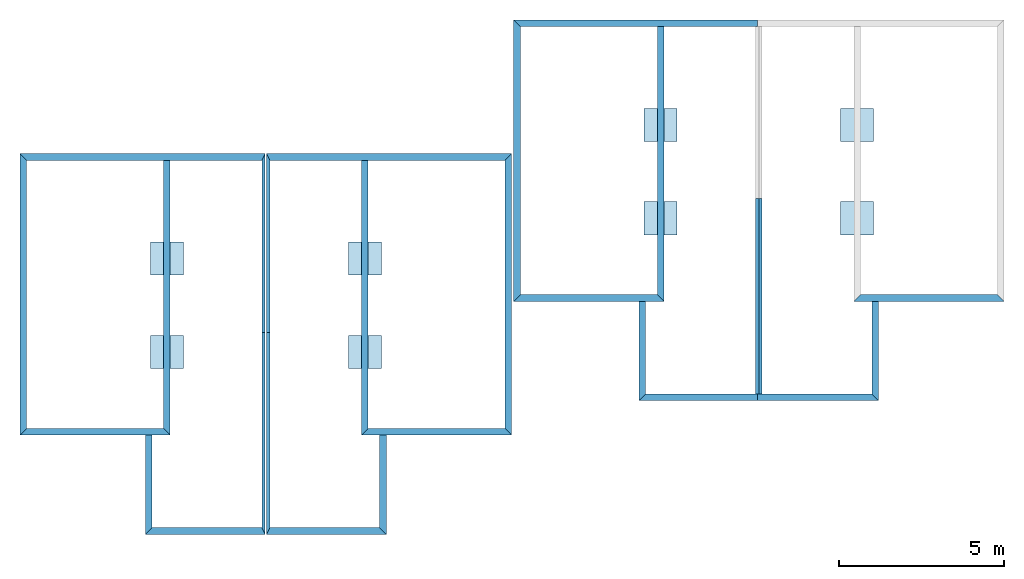
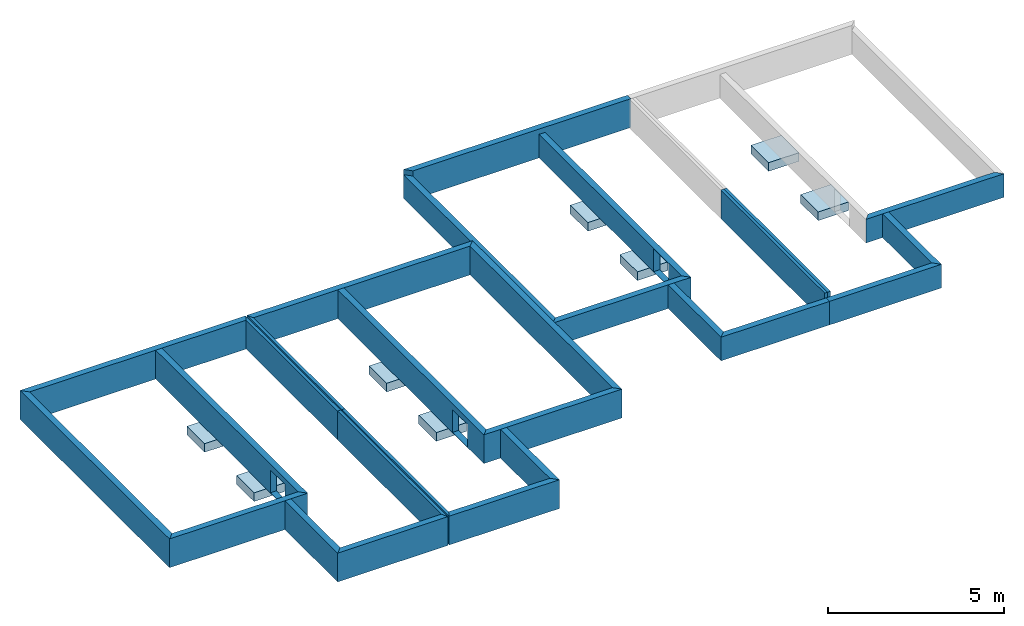
# One storey, part 1 of 2: 27 walls, 8 slabs, 3 openings.
"""IFC2X3 building model written with IfcOpenShell, lengths in metres."""

from ifc_helpers import new_model, entity, si_unit, converted_unit, derived_unit, money_unit, direction, frame, origin_with_axes, origin_2d_with_axis, place, context, subcontext, project, spatial, polyline, rectangle, outline, extrude, clip, halfspace, bounded_halfspace, faceted_brep, material, layer, layer_set, layer_usage, type_object, element, save


model = new_model("IFC2X3")

# Units and contexts
model_context = context("Model", 3, precision=1e-05, world=origin_with_axes(), true_north=direction((0.0, 1.0)))
body_context = subcontext(model_context, "Body", "Model", "MODEL_VIEW")
ifc_project = project(units=[si_unit("LENGTHUNIT", "METRE"), si_unit("AREAUNIT", "SQUARE_METRE"), si_unit("VOLUMEUNIT", "CUBIC_METRE"), converted_unit("PLANEANGLEUNIT", "DEGREE", entity("IfcPlaneAngleMeasure", 0.0174532925199), si_unit("PLANEANGLEUNIT", "RADIAN"), dimensions=[0, 0, 0, 0, 0, 0, 0]), si_unit("SOLIDANGLEUNIT", "STERADIAN"), money_unit("CHF"), converted_unit("TIMEUNIT", "Year", entity("IfcTimeMeasure", 31556926.0), si_unit("TIMEUNIT", "SECOND"), dimensions=[0, 0, 1, 0, 0, 0, 0]), si_unit("MASSUNIT", "GRAM", prefix="KILO"), si_unit("THERMODYNAMICTEMPERATUREUNIT", "DEGREE_CELSIUS"), si_unit("LUMINOUSINTENSITYUNIT", "LUMEN"), si_unit("ENERGYUNIT", "JOULE", prefix="MEGA"), derived_unit("THERMALCONDUCTANCEUNIT", [(si_unit("POWERUNIT", "WATT"), 1), (si_unit("LENGTHUNIT", "METRE"), -1), (si_unit("THERMODYNAMICTEMPERATUREUNIT", "KELVIN"), -1)]), derived_unit("SPECIFICHEATCAPACITYUNIT", [(si_unit("ENERGYUNIT", "JOULE"), 1), (si_unit("MASSUNIT", "GRAM", prefix="KILO"), -1), (si_unit("THERMODYNAMICTEMPERATUREUNIT", "KELVIN"), -1)]), derived_unit("MASSDENSITYUNIT", [(si_unit("MASSUNIT", "GRAM", prefix="KILO"), 1), (si_unit("VOLUMEUNIT", "CUBIC_METRE"), -1)])], contexts=[model_context])

# Site, building, storey
site_placement = place(None, origin_with_axes())
site = spatial("IfcSite", under=ifc_project, at=site_placement, CompositionType="ELEMENT")
building_placement = place(site_placement, origin_with_axes())
building = spatial("IfcBuilding", under=site, at=building_placement, CompositionType="ELEMENT")
storey_placement = place(building_placement, frame((0.0, 0.0, -0.8), z_axis=(0.0, 0.0, 1.0), x_axis=(1.0, 0.0, 0.0)))
storey = spatial("IfcBuildingStorey", under=building, at=storey_placement, Name="vs", CompositionType="ELEMENT", Elevation=-0.8)

# Slabs
ifc_material_1 = material()
slab_type_1 = type_object("IfcSlabType", Name="Dalle 1", PredefinedType="FLOOR")
slab_1_placement = place(storey_placement, origin_with_axes())
element("IfcSlab", 1, at=slab_1_placement, inside=storey, type_object=slab_type_1, material=ifc_material_1, Name="Base rectangulaire:1.00 x 1.00 x .30", PredefinedType="FLOOR", context=body_context, shape_type="Brep", body=[
    faceted_brep([(86.196785775, 89.777523968, -0.5), (86.196785775, 88.777523968, -0.5), (86.196785775, 88.777523968, -0.2), (86.196785775, 89.777523968, -0.2), (87.196785775, 89.777523968, -0.5), (87.196785775, 88.777523968, -0.5), (87.196785775, 88.777523968, -0.2), (87.196785775, 89.777523968, -0.2)], [[[0, 1, 2, 3]], [[0, 4, 5, 1]], [[1, 5, 6, 2]], [[3, 2, 6, 7]], [[4, 0, 3, 7]], [[5, 4, 7, 6]]]),
    faceted_brep([(86.196785775, 89.777523968, -0.5), (86.196785775, 88.777523968, -0.5), (86.196785775, 88.777523968, -0.2), (86.196785775, 89.777523968, -0.2), (87.196785775, 89.777523968, -0.5), (87.196785775, 88.777523968, -0.5), (87.196785775, 88.777523968, -0.2), (87.196785775, 89.777523968, -0.2)], [[[0, 1, 2, 3]], [[0, 4, 5, 1]], [[1, 5, 6, 2]], [[3, 2, 6, 7]], [[4, 0, 3, 7]], [[5, 4, 7, 6]]]),
])
slab_type_2 = type_object("IfcSlabType", Name="Dalle 2", PredefinedType="FLOOR")
slab_2_placement = place(storey_placement, origin_with_axes())
element("IfcSlab", 2, at=slab_2_placement, inside=storey, type_object=slab_type_2, material=ifc_material_1, Name="Base rectangulaire:1.00 x 1.00 x .30", PredefinedType="FLOOR", context=body_context, shape_type="Brep", body=[
    faceted_brep([(71.324626364, 85.7377566782, -0.5), (71.324626364, 84.7377566782, -0.5), (71.324626364, 84.7377566782, -0.2), (71.324626364, 85.7377566782, -0.2), (72.324626364, 85.7377566782, -0.5), (72.324626364, 84.7377566782, -0.5), (72.324626364, 84.7377566782, -0.2), (72.324626364, 85.7377566782, -0.2)], [[[0, 1, 2, 3]], [[0, 4, 5, 1]], [[1, 5, 6, 2]], [[3, 2, 6, 7]], [[4, 0, 3, 7]], [[5, 4, 7, 6]]]),
    faceted_brep([(71.324626364, 85.7377566782, -0.5), (71.324626364, 84.7377566782, -0.5), (71.324626364, 84.7377566782, -0.2), (71.324626364, 85.7377566782, -0.2), (72.324626364, 85.7377566782, -0.5), (72.324626364, 84.7377566782, -0.5), (72.324626364, 84.7377566782, -0.2), (72.324626364, 85.7377566782, -0.2)], [[[0, 1, 2, 3]], [[0, 4, 5, 1]], [[1, 5, 6, 2]], [[3, 2, 6, 7]], [[4, 0, 3, 7]], [[5, 4, 7, 6]]]),
])
slab_type_3 = type_object("IfcSlabType", Name="Dalle 3", PredefinedType="FLOOR")
slab_3_placement = place(storey_placement, origin_with_axes())
element("IfcSlab", 3, at=slab_3_placement, inside=storey, type_object=slab_type_3, material=ifc_material_1, Name="Base rectangulaire:1.00 x 1.00 x .30", PredefinedType="FLOOR", context=body_context, shape_type="Brep", body=[
    faceted_brep([(65.344626364, 84.7377566782, -0.5), (66.344626364, 84.7377566782, -0.5), (66.344626364, 84.7377566782, -0.2), (65.344626364, 84.7377566782, -0.2), (65.344626364, 85.7377566782, -0.5), (66.344626364, 85.7377566782, -0.5), (66.344626364, 85.7377566782, -0.2), (65.344626364, 85.7377566782, -0.2)], [[[0, 1, 2, 3]], [[0, 4, 5, 1]], [[1, 5, 6, 2]], [[3, 2, 6, 7]], [[4, 0, 3, 7]], [[5, 4, 7, 6]]]),
    faceted_brep([(65.344626364, 84.7377566782, -0.5), (66.344626364, 84.7377566782, -0.5), (66.344626364, 84.7377566782, -0.2), (65.344626364, 84.7377566782, -0.2), (65.344626364, 85.7377566782, -0.5), (66.344626364, 85.7377566782, -0.5), (66.344626364, 85.7377566782, -0.2), (65.344626364, 85.7377566782, -0.2)], [[[0, 1, 2, 3]], [[0, 4, 5, 1]], [[1, 5, 6, 2]], [[3, 2, 6, 7]], [[4, 0, 3, 7]], [[5, 4, 7, 6]]]),
])
slab_type_4 = type_object("IfcSlabType", Name="Dalle 4", PredefinedType="FLOOR")
slab_4_placement = place(storey_placement, origin_with_axes())
element("IfcSlab", 4, at=slab_4_placement, inside=storey, type_object=slab_type_4, material=ifc_material_1, Name="Base rectangulaire:1.00 x 1.00 x .30", PredefinedType="FLOOR", context=body_context, shape_type="Brep", body=[
    faceted_brep([(86.196785775, 86.957523968, -0.5), (86.196785775, 85.957523968, -0.5), (86.196785775, 85.957523968, -0.2), (86.196785775, 86.957523968, -0.2), (87.196785775, 86.957523968, -0.5), (87.196785775, 85.957523968, -0.5), (87.196785775, 85.957523968, -0.2), (87.196785775, 86.957523968, -0.2)], [[[0, 1, 2, 3]], [[0, 4, 5, 1]], [[1, 5, 6, 2]], [[3, 2, 6, 7]], [[4, 0, 3, 7]], [[5, 4, 7, 6]]]),
    faceted_brep([(86.196785775, 86.957523968, -0.5), (86.196785775, 85.957523968, -0.5), (86.196785775, 85.957523968, -0.2), (86.196785775, 86.957523968, -0.2), (87.196785775, 86.957523968, -0.5), (87.196785775, 85.957523968, -0.5), (87.196785775, 85.957523968, -0.2), (87.196785775, 86.957523968, -0.2)], [[[0, 1, 2, 3]], [[0, 4, 5, 1]], [[1, 5, 6, 2]], [[3, 2, 6, 7]], [[4, 0, 3, 7]], [[5, 4, 7, 6]]]),
])
slab_type_5 = type_object("IfcSlabType", Name="Dalle 5", PredefinedType="FLOOR")
slab_5_placement = place(storey_placement, origin_with_axes())
element("IfcSlab", 5, at=slab_5_placement, inside=storey, type_object=slab_type_5, material=ifc_material_1, Name="Base rectangulaire:1.00 x 1.00 x .30", PredefinedType="FLOOR", context=body_context, shape_type="Brep", body=[
    faceted_brep([(71.324626364, 82.9177566782, -0.5), (71.324626364, 81.9177566782, -0.5), (71.324626364, 81.9177566782, -0.2), (71.324626364, 82.9177566782, -0.2), (72.324626364, 82.9177566782, -0.5), (72.324626364, 81.9177566782, -0.5), (72.324626364, 81.9177566782, -0.2), (72.324626364, 82.9177566782, -0.2)], [[[0, 1, 2, 3]], [[0, 4, 5, 1]], [[1, 5, 6, 2]], [[3, 2, 6, 7]], [[4, 0, 3, 7]], [[5, 4, 7, 6]]]),
    faceted_brep([(71.324626364, 82.9177566782, -0.5), (71.324626364, 81.9177566782, -0.5), (71.324626364, 81.9177566782, -0.2), (71.324626364, 82.9177566782, -0.2), (72.324626364, 82.9177566782, -0.5), (72.324626364, 81.9177566782, -0.5), (72.324626364, 81.9177566782, -0.2), (72.324626364, 82.9177566782, -0.2)], [[[0, 1, 2, 3]], [[0, 4, 5, 1]], [[1, 5, 6, 2]], [[3, 2, 6, 7]], [[4, 0, 3, 7]], [[5, 4, 7, 6]]]),
])
slab_type_6 = type_object("IfcSlabType", Name="Dalle 6", PredefinedType="FLOOR")
slab_6_placement = place(storey_placement, origin_with_axes())
element("IfcSlab", 6, at=slab_6_placement, inside=storey, type_object=slab_type_6, material=ifc_material_1, Name="Base rectangulaire:1.00 x 1.00 x .30", PredefinedType="FLOOR", context=body_context, shape_type="Brep", body=[
    faceted_brep([(65.344626364, 81.9177566782, -0.5), (66.344626364, 81.9177566782, -0.5), (66.344626364, 81.9177566782, -0.2), (65.344626364, 81.9177566782, -0.2), (65.344626364, 82.9177566782, -0.5), (66.344626364, 82.9177566782, -0.5), (66.344626364, 82.9177566782, -0.2), (65.344626364, 82.9177566782, -0.2)], [[[0, 1, 2, 3]], [[0, 4, 5, 1]], [[1, 5, 6, 2]], [[3, 2, 6, 7]], [[4, 0, 3, 7]], [[5, 4, 7, 6]]]),
    faceted_brep([(65.344626364, 81.9177566782, -0.5), (66.344626364, 81.9177566782, -0.5), (66.344626364, 81.9177566782, -0.2), (65.344626364, 81.9177566782, -0.2), (65.344626364, 82.9177566782, -0.5), (66.344626364, 82.9177566782, -0.5), (66.344626364, 82.9177566782, -0.2), (65.344626364, 82.9177566782, -0.2)], [[[0, 1, 2, 3]], [[0, 4, 5, 1]], [[1, 5, 6, 2]], [[3, 2, 6, 7]], [[4, 0, 3, 7]], [[5, 4, 7, 6]]]),
])
slab_type_7 = type_object("IfcSlabType", Name="Dalle 7", PredefinedType="FLOOR")
slab_7_placement = place(storey_placement, origin_with_axes())
element("IfcSlab", 7, at=slab_7_placement, inside=storey, type_object=slab_type_7, material=ifc_material_1, Name="Base rectangulaire:1.00 x 1.00 x .30", PredefinedType="FLOOR", context=body_context, shape_type="Brep", body=[
    faceted_brep([(80.2610189554, 88.777523968, -0.5), (81.2610189554, 88.777523968, -0.5), (81.2610189554, 88.777523968, -0.2), (80.2610189554, 88.777523968, -0.2), (80.2610189554, 89.777523968, -0.5), (81.2610189554, 89.777523968, -0.5), (81.2610189554, 89.777523968, -0.2), (80.2610189554, 89.777523968, -0.2)], [[[0, 1, 2, 3]], [[0, 4, 5, 1]], [[1, 5, 6, 2]], [[3, 2, 6, 7]], [[4, 0, 3, 7]], [[5, 4, 7, 6]]]),
    faceted_brep([(80.2610189554, 88.777523968, -0.5), (81.2610189554, 88.777523968, -0.5), (81.2610189554, 88.777523968, -0.2), (80.2610189554, 88.777523968, -0.2), (80.2610189554, 89.777523968, -0.5), (81.2610189554, 89.777523968, -0.5), (81.2610189554, 89.777523968, -0.2), (80.2610189554, 89.777523968, -0.2)], [[[0, 1, 2, 3]], [[0, 4, 5, 1]], [[1, 5, 6, 2]], [[3, 2, 6, 7]], [[4, 0, 3, 7]], [[5, 4, 7, 6]]]),
])
slab_type_8 = type_object("IfcSlabType", Name="Dalle 8", PredefinedType="FLOOR")
slab_8_placement = place(storey_placement, origin_with_axes())
element("IfcSlab", 8, at=slab_8_placement, inside=storey, type_object=slab_type_8, material=ifc_material_1, Name="Base rectangulaire:1.00 x 1.00 x .30", PredefinedType="FLOOR", context=body_context, shape_type="Brep", body=[
    faceted_brep([(80.2610189554, 85.957523968, -0.5), (81.2610189554, 85.957523968, -0.5), (81.2610189554, 85.957523968, -0.2), (80.2610189554, 85.957523968, -0.2), (80.2610189554, 86.957523968, -0.5), (81.2610189554, 86.957523968, -0.5), (81.2610189554, 86.957523968, -0.2), (80.2610189554, 86.957523968, -0.2)], [[[0, 1, 2, 3]], [[0, 4, 5, 1]], [[1, 5, 6, 2]], [[3, 2, 6, 7]], [[4, 0, 3, 7]], [[5, 4, 7, 6]]]),
    faceted_brep([(80.2610189554, 85.957523968, -0.5), (81.2610189554, 85.957523968, -0.5), (81.2610189554, 85.957523968, -0.2), (80.2610189554, 85.957523968, -0.2), (80.2610189554, 86.957523968, -0.5), (81.2610189554, 86.957523968, -0.5), (81.2610189554, 86.957523968, -0.2), (80.2610189554, 86.957523968, -0.2)], [[[0, 1, 2, 3]], [[0, 4, 5, 1]], [[1, 5, 6, 2]], [[3, 2, 6, 7]], [[4, 0, 3, 7]], [[5, 4, 7, 6]]]),
])

# Walls
ifc_material_2 = material(Name="Parpaing")
ifc_layer_1 = layer(ifc_material_2, 0.2, ventilated="UNKNOWN")
ifc_layer_set_1 = layer_set([ifc_layer_1], Name="Parpaing 0.2")
ifc_layer_usage_1 = layer_usage(ifc_layer_set_1, "AXIS2", "POSITIVE", -0.1)
wall_type_1 = type_object("IfcWallType", Name="Mur de base:Ext. Parpaing 20", PredefinedType="STANDARD")
wall_1_placement = place(storey_placement, frame((91.0350487235, 84.047523968, -0.2), z_axis=(0.0, 0.0, 1.0), x_axis=(-1.0, 0.0, 0.0)))
element("IfcWallStandardCase", 9, at=wall_1_placement, inside=storey, type_object=wall_type_1, material=ifc_layer_usage_1, Name="Mur de base:Ext. Parpaing 20", ObjectType="STANDARD", context=body_context, shape_type="Clipping", body=[
    clip(extrude(outline(polyline([(0.1, -0.1), (4.23826294855, -0.1), (4.43826294855, 0.1), (-0.1, 0.1), (0.1, -0.1)])), origin_with_axes(), (0.0, 0.0, 1.0), 0.82), bounded_halfspace(frame((0.0, 0.0, 0.82), z_axis=(0.0, 0.0, -1.0), x_axis=(0.0, 1.0, 0.0)), True, origin_with_axes(), polyline([(3.88826292789, -0.11), (8.85786987799, -0.11), (8.85786987799, 0.11), (3.88826292789, 0.11), (3.88826292789, -0.11)]))),
])
ifc_layer_usage_2 = layer_usage(ifc_layer_set_1, "AXIS2", "POSITIVE", -0.1)
wall_2_placement = place(storey_placement, frame((83.6810189554, 81.047523968, -0.2), z_axis=(0.0, 0.0, 1.0), x_axis=(1.0, 0.0, 0.0)))
element("IfcWallStandardCase", 10, at=wall_2_placement, inside=storey, type_object=wall_type_1, material=ifc_layer_usage_2, Name="Mur de base:Ext. Parpaing 20", ObjectType="STANDARD", context=body_context, shape_type="SweptSolid", body=[
    extrude(outline(polyline([(0.0, -0.1), (3.66576681958, -0.1), (3.46576681958, 0.1), (0.0, 0.1), (0.0, -0.1)])), origin_with_axes(), (0.0, 0.0, 1.0), 0.82),
])
ifc_layer_usage_3 = layer_usage(ifc_layer_set_1, "AXIS2", "POSITIVE", -0.1)
wall_3_placement = place(storey_placement, frame((87.246785775, 81.047523968, -0.2), z_axis=(0.0, 0.0, 1.0), x_axis=(0.0, 1.0, 0.0)))
element("IfcWallStandardCase", 11, at=wall_3_placement, inside=storey, type_object=wall_type_1, material=ifc_layer_usage_3, Name="Mur de base:Ext. Parpaing 20", ObjectType="STANDARD", context=body_context, shape_type="SweptSolid", body=[
    extrude(outline(polyline([(-0.1, -0.1), (2.9, -0.1), (2.9, 0.1), (0.1, 0.1), (-0.1, -0.1)])), origin_with_axes(), (0.0, 0.0, 1.0), 0.82),
])
ifc_layer_usage_4 = layer_usage(ifc_layer_set_1, "AXIS2", "POSITIVE", -0.1)
wall_4_placement = place(storey_placement, frame((68.904626364, 88.3077566782, -0.2), z_axis=(0.0, 0.0, 1.0), x_axis=(1.0, 0.0, 0.0)))
element("IfcWallStandardCase", 12, at=wall_4_placement, inside=storey, type_object=wall_type_1, material=ifc_layer_usage_4, Name="Mur de base:Ext. Parpaing 20", ObjectType="STANDARD", context=body_context, shape_type="SweptSolid", body=[
    extrude(outline(polyline([(0.05, -0.1), (7.15826294855, -0.1), (7.35826294855, 0.1), (-0.05, 0.1), (0.05, -0.1)])), origin_with_axes(), (0.0, 0.0, 1.0), 1.0),
])
ifc_layer_usage_5 = layer_usage(ifc_layer_set_1, "AXIS2", "POSITIVE", -0.1)
wall_5_placement = place(storey_placement, frame((76.1628893125, 88.3077566782, -0.2), z_axis=(0.0, 0.0, 1.0), x_axis=(0.0, -1.0, 0.0)))
element("IfcWallStandardCase", 13, at=wall_5_placement, inside=storey, type_object=wall_type_1, material=ifc_layer_usage_5, Name="Mur de base:Ext. Parpaing 20", ObjectType="STANDARD", context=body_context, shape_type="SweptSolid", body=[
    extrude(outline(polyline([(0.1, -0.1), (8.2, -0.1), (8.4, 0.1), (-0.1, 0.1), (0.1, -0.1)])), origin_with_axes(), (0.0, 0.0, 1.0), 1.0),
])
ifc_layer_usage_6 = layer_usage(ifc_layer_set_1, "AXIS2", "POSITIVE", -0.1)
wall_6_placement = place(storey_placement, frame((76.1628893125, 80.0077566782, -0.2), z_axis=(0.0, 0.0, 1.0), x_axis=(-1.0, 0.0, 0.0)))
element("IfcWallStandardCase", 14, at=wall_6_placement, inside=storey, type_object=wall_type_1, material=ifc_layer_usage_6, Name="Mur de base:Ext. Parpaing 20", ObjectType="STANDARD", context=body_context, shape_type="SweptSolid", body=[
    extrude(outline(polyline([(0.1, -0.1), (4.23826294855, -0.1), (4.43826294855, 0.1), (-0.1, 0.1), (0.1, -0.1)])), origin_with_axes(), (0.0, 0.0, 1.0), 1.0),
])
ifc_layer_usage_7 = layer_usage(ifc_layer_set_1, "AXIS2", "POSITIVE", -0.1)
wall_7_placement = place(storey_placement, frame((68.904626364, 77.0077566782, -0.2), z_axis=(0.0, 0.0, 1.0), x_axis=(1.0, 0.0, 0.0)))
element("IfcWallStandardCase", 15, at=wall_7_placement, inside=storey, type_object=wall_type_1, material=ifc_layer_usage_7, Name="Mur de base:Ext. Parpaing 20", ObjectType="STANDARD", context=body_context, shape_type="SweptSolid", body=[
    extrude(outline(polyline([(-0.05, -0.1), (3.57, -0.1), (3.37, 0.1), (0.05, 0.1), (-0.05, -0.1)])), origin_with_axes(), (0.0, 0.0, 1.0), 1.0),
])
ifc_layer_usage_8 = layer_usage(ifc_layer_set_1, "AXIS2", "POSITIVE", -0.1)
wall_8_placement = place(storey_placement, frame((72.374626364, 77.0077566782, -0.2), z_axis=(0.0, 0.0, 1.0), x_axis=(0.0, 1.0, 0.0)))
element("IfcWallStandardCase", 16, at=wall_8_placement, inside=storey, type_object=wall_type_1, material=ifc_layer_usage_8, Name="Mur de base:Ext. Parpaing 20", ObjectType="STANDARD", context=body_context, shape_type="SweptSolid", body=[
    extrude(outline(polyline([(-0.1, -0.1), (2.9, -0.1), (2.9, 0.1), (0.1, 0.1), (-0.1, -0.1)])), origin_with_axes(), (0.0, 0.0, 1.0), 1.0),
])

# Wall, opening
ifc_layer_usage_9 = layer_usage(ifc_layer_set_1, "AXIS2", "POSITIVE", -0.1)
wall_9_placement = place(storey_placement, frame((71.824626364, 80.0077566782, -0.2), z_axis=(0.0, 0.0, 1.0), x_axis=(0.0, 1.0, 0.0)))
wall_9 = element("IfcWallStandardCase", 17, at=wall_9_placement, inside=storey, type_object=wall_type_1, material=ifc_layer_usage_9, Name="Mur de base:Ext. Parpaing 20", ObjectType="STANDARD", context=body_context, shape_type="SweptSolid", body=[
    extrude(outline(polyline([(0.1, -0.1), (8.2, -0.1), (8.2, 0.1), (-0.1, 0.1), (0.1, -0.1)])), origin_with_axes(), (0.0, 0.0, 1.0), 1.0),
])
opening_1_placement = place(wall_9_placement, frame((-80.0077566782, 71.824626364, 1.0), z_axis=(0.0, 0.0, 1.0), x_axis=(0.0, -1.0, 0.0)))
element("IfcOpeningElement", 18, at=opening_1_placement, cuts=wall_9, Name="Mur de base:Ext. Parpaing 20", context=body_context, shape_type="SweptSolid", body=[
    extrude(rectangle(XDim=0.793145708582, YDim=0.840999406834, at=origin_2d_with_axis()), frame((71.924626364, 81.266599442, -0.596572854291), z_axis=(-1.0, 0.0, 0.0), x_axis=(0.0, 0.0, -1.0)), (0.0, 0.0, 1.0), 0.2),
])

# Walls
ifc_layer_usage_10 = layer_usage(ifc_layer_set_1, "AXIS2", "POSITIVE", -0.1)
wall_10_placement = place(storey_placement, frame((68.764626364, 88.3077566782, -0.2), z_axis=(0.0, 0.0, 1.0), x_axis=(-1.0, 0.0, 0.0)))
element("IfcWallStandardCase", 19, at=wall_10_placement, inside=storey, type_object=wall_type_1, material=ifc_layer_usage_10, Name="Mur de base:Ext. Parpaing 20", ObjectType="STANDARD", context=body_context, shape_type="SweptSolid", body=[
    extrude(outline(polyline([(-0.05, -0.1), (7.35826294855, -0.1), (7.15826294855, 0.1), (0.05, 0.1), (-0.05, -0.1)])), origin_with_axes(), (0.0, 0.0, 1.0), 1.0),
])
ifc_layer_usage_11 = layer_usage(ifc_layer_set_1, "AXIS2", "POSITIVE", -0.1)
wall_11_placement = place(storey_placement, frame((61.5063634154, 88.3077566782, -0.2), z_axis=(0.0, 0.0, 1.0), x_axis=(0.0, -1.0, 0.0)))
element("IfcWallStandardCase", 20, at=wall_11_placement, inside=storey, type_object=wall_type_1, material=ifc_layer_usage_11, Name="Mur de base:Ext. Parpaing 20", ObjectType="STANDARD", context=body_context, shape_type="SweptSolid", body=[
    extrude(outline(polyline([(-0.1, -0.1), (8.4, -0.1), (8.2, 0.1), (0.1, 0.1), (-0.1, -0.1)])), origin_with_axes(), (0.0, 0.0, 1.0), 1.0),
])
ifc_layer_usage_12 = layer_usage(ifc_layer_set_1, "AXIS2", "POSITIVE", -0.1)
wall_12_placement = place(storey_placement, frame((61.5063634154, 80.0077566782, -0.2), z_axis=(0.0, 0.0, 1.0), x_axis=(1.0, 0.0, 0.0)))
element("IfcWallStandardCase", 21, at=wall_12_placement, inside=storey, type_object=wall_type_1, material=ifc_layer_usage_12, Name="Mur de base:Ext. Parpaing 20", ObjectType="STANDARD", context=body_context, shape_type="SweptSolid", body=[
    extrude(outline(polyline([(-0.1, -0.1), (4.43826294855, -0.1), (4.23826294855, 0.1), (0.1, 0.1), (-0.1, -0.1)])), origin_with_axes(), (0.0, 0.0, 1.0), 1.0),
])
ifc_layer_usage_13 = layer_usage(ifc_layer_set_1, "AXIS2", "POSITIVE", -0.1)
wall_13_placement = place(storey_placement, frame((68.764626364, 77.0077566782, -0.2), z_axis=(0.0, 0.0, 1.0), x_axis=(-1.0, 0.0, 0.0)))
element("IfcWallStandardCase", 22, at=wall_13_placement, inside=storey, type_object=wall_type_1, material=ifc_layer_usage_13, Name="Mur de base:Ext. Parpaing 20", ObjectType="STANDARD", context=body_context, shape_type="SweptSolid", body=[
    extrude(outline(polyline([(0.05, -0.1), (3.37, -0.1), (3.57, 0.1), (-0.05, 0.1), (0.05, -0.1)])), origin_with_axes(), (0.0, 0.0, 1.0), 1.0),
])
ifc_layer_usage_14 = layer_usage(ifc_layer_set_1, "AXIS2", "POSITIVE", -0.1)
wall_14_placement = place(storey_placement, frame((65.294626364, 77.0077566782, -0.2), z_axis=(0.0, 0.0, 1.0), x_axis=(0.0, 1.0, 0.0)))
element("IfcWallStandardCase", 23, at=wall_14_placement, inside=storey, type_object=wall_type_1, material=ifc_layer_usage_14, Name="Mur de base:Ext. Parpaing 20", ObjectType="STANDARD", context=body_context, shape_type="SweptSolid", body=[
    extrude(outline(polyline([(0.1, -0.1), (2.9, -0.1), (2.9, 0.1), (-0.1, 0.1), (0.1, -0.1)])), origin_with_axes(), (0.0, 0.0, 1.0), 1.0),
])

# Wall, opening
ifc_layer_usage_15 = layer_usage(ifc_layer_set_1, "AXIS2", "POSITIVE", -0.1)
wall_15_placement = place(storey_placement, frame((65.844626364, 80.0077566782, -0.2), z_axis=(0.0, 0.0, 1.0), x_axis=(0.0, 1.0, 0.0)))
wall_15 = element("IfcWallStandardCase", 24, at=wall_15_placement, inside=storey, type_object=wall_type_1, material=ifc_layer_usage_15, Name="Mur de base:Ext. Parpaing 20", ObjectType="STANDARD", context=body_context, shape_type="SweptSolid", body=[
    extrude(outline(polyline([(-0.1, -0.1), (8.2, -0.1), (8.2, 0.1), (0.1, 0.1), (-0.1, -0.1)])), origin_with_axes(), (0.0, 0.0, 1.0), 1.0),
])
opening_2_placement = place(wall_15_placement, frame((-80.0077566782, 65.844626364, 1.0), z_axis=(0.0, 0.0, 1.0), x_axis=(0.0, -1.0, 0.0)))
element("IfcOpeningElement", 25, at=opening_2_placement, cuts=wall_15, Name="Mur de base:Ext. Parpaing 20", context=body_context, shape_type="SweptSolid", body=[
    extrude(rectangle(XDim=0.793145708582, YDim=0.840999406834, at=origin_2d_with_axis()), frame((65.944626364, 81.266599442, -0.596572854291), z_axis=(-1.0, 0.0, 0.0), x_axis=(0.0, 0.0, -1.0)), (0.0, 0.0, 1.0), 0.2),
])

# Walls
ifc_layer_usage_16 = layer_usage(ifc_layer_set_1, "AXIS2", "POSITIVE", -0.1)
wall_16_placement = place(storey_placement, frame((83.6810189554, 92.347523968, -0.2), z_axis=(0.0, 0.0, 1.0), x_axis=(-1.0, 0.0, 0.0)))
element("IfcWallStandardCase", 26, at=wall_16_placement, inside=storey, type_object=wall_type_1, material=ifc_layer_usage_16, Name="Mur de base:Ext. Parpaing 20", ObjectType="STANDARD", context=body_context, shape_type="SweptSolid", body=[
    extrude(outline(polyline([(0.0, -0.1), (7.35826294855, -0.1), (7.15826294855, 0.1), (0.0, 0.1), (0.0, -0.1)])), origin_with_axes(), (0.0, 0.0, 1.0), 1.0),
])
ifc_layer_usage_17 = layer_usage(ifc_layer_set_1, "AXIS2", "POSITIVE", -0.1)
wall_17_placement = place(storey_placement, frame((76.4227560068, 92.347523968, -0.2), z_axis=(0.0, 0.0, 1.0), x_axis=(0.0, -1.0, 0.0)))
element("IfcWallStandardCase", 27, at=wall_17_placement, inside=storey, type_object=wall_type_1, material=ifc_layer_usage_17, Name="Mur de base:Ext. Parpaing 20", ObjectType="STANDARD", context=body_context, shape_type="SweptSolid", body=[
    extrude(outline(polyline([(-0.1, -0.1), (8.4, -0.1), (8.2, 0.1), (0.1, 0.1), (-0.1, -0.1)])), origin_with_axes(), (0.0, 0.0, 1.0), 0.82),
])
ifc_layer_usage_18 = layer_usage(ifc_layer_set_1, "AXIS2", "POSITIVE", -0.1)
wall_18_placement = place(storey_placement, frame((76.4227560068, 84.047523968, -0.2), z_axis=(0.0, 0.0, 1.0), x_axis=(1.0, 0.0, 0.0)))
element("IfcWallStandardCase", 28, at=wall_18_placement, inside=storey, type_object=wall_type_1, material=ifc_layer_usage_18, Name="Mur de base:Ext. Parpaing 20", ObjectType="STANDARD", context=body_context, shape_type="Clipping", body=[
    clip(extrude(outline(polyline([(-0.1, -0.1), (4.43826294855, -0.1), (4.23826294855, 0.1), (0.1, 0.1), (-0.1, -0.1)])), origin_with_axes(), (0.0, 0.0, 1.0), 0.82), bounded_halfspace(frame((0.0, 0.0, 0.82), z_axis=(0.0, 0.0, -1.0), x_axis=(0.0, 1.0, 0.0)), True, origin_with_axes(), polyline([(3.88826292789, -0.11), (8.85786987799, -0.11), (8.85786987799, 0.11), (3.88826292789, 0.11), (3.88826292789, -0.11)]))),
])
ifc_layer_usage_19 = layer_usage(ifc_layer_set_1, "AXIS2", "POSITIVE", -0.1)
wall_19_placement = place(storey_placement, frame((83.6810189554, 81.047523968, -0.2), z_axis=(0.0, 0.0, 1.0), x_axis=(-1.0, 0.0, 0.0)))
element("IfcWallStandardCase", 29, at=wall_19_placement, inside=storey, type_object=wall_type_1, material=ifc_layer_usage_19, Name="Mur de base:Ext. Parpaing 20", ObjectType="STANDARD", context=body_context, shape_type="SweptSolid", body=[
    extrude(outline(polyline([(0.0, -0.1), (3.37, -0.1), (3.57, 0.1), (0.0, 0.1), (0.0, -0.1)])), origin_with_axes(), (0.0, 0.0, 1.0), 0.82),
])
ifc_layer_usage_20 = layer_usage(ifc_layer_set_1, "AXIS2", "POSITIVE", -0.1)
wall_20_placement = place(storey_placement, frame((80.2110189554, 81.047523968, -0.2), z_axis=(0.0, 0.0, 1.0), x_axis=(0.0, 1.0, 0.0)))
element("IfcWallStandardCase", 30, at=wall_20_placement, inside=storey, type_object=wall_type_1, material=ifc_layer_usage_20, Name="Mur de base:Ext. Parpaing 20", ObjectType="STANDARD", context=body_context, shape_type="SweptSolid", body=[
    extrude(outline(polyline([(0.1, -0.1), (2.9, -0.1), (2.9, 0.1), (-0.1, 0.1), (0.1, -0.1)])), origin_with_axes(), (0.0, 0.0, 1.0), 0.82),
])

# Wall, opening
ifc_layer_usage_21 = layer_usage(ifc_layer_set_1, "AXIS2", "POSITIVE", -0.1)
wall_21_placement = place(storey_placement, frame((80.7610189554, 84.047523968, -0.2), z_axis=(0.0, 0.0, 1.0), x_axis=(0.0, 1.0, 0.0)))
wall_21 = element("IfcWallStandardCase", 31, at=wall_21_placement, inside=storey, type_object=wall_type_1, material=ifc_layer_usage_21, Name="Mur de base:Ext. Parpaing 20", ObjectType="STANDARD", context=body_context, shape_type="Clipping", body=[
    clip(extrude(outline(polyline([(-0.1, -0.1), (8.2, -0.1), (8.2, 0.1), (0.1, 0.1), (-0.1, -0.1)])), origin_with_axes(), (0.0, 0.0, 1.0), 0.82), halfspace(frame((0.0, 0.0, 0.82), z_axis=(0.0, 0.0, -1.0), x_axis=(0.0, 1.0, 0.0)), True)),
])
opening_3_placement = place(wall_21_placement, frame((-84.047523968, 80.7610189554, 1.0), z_axis=(0.0, 0.0, 1.0), x_axis=(0.0, -1.0, 0.0)))
element("IfcOpeningElement", 32, at=opening_3_placement, cuts=wall_21, Name="Mur de base:Ext. Parpaing 20", context=body_context, shape_type="SweptSolid", body=[
    extrude(rectangle(XDim=0.793145708582, YDim=0.840999406834, at=origin_2d_with_axis()), frame((80.8610189554, 85.3063667318, -0.596572854291), z_axis=(-1.0, 0.0, 0.0), x_axis=(0.0, 0.0, -1.0)), (0.0, 0.0, 1.0), 0.2),
])

# Walls
ifc_layer_2 = layer(ifc_material_2, 0.1, ventilated="UNKNOWN")
ifc_layer_set_2 = layer_set([ifc_layer_2], Name="Parpaing 0.1")
ifc_layer_usage_22 = layer_usage(ifc_layer_set_2, "AXIS2", "POSITIVE", -0.05)
wall_type_2 = type_object("IfcWallType", Name="Mur de base:Ext. Parpaing 10", PredefinedType="STANDARD")
wall_22_placement = place(storey_placement, frame((83.776785775, 87.0513363421, -0.2), z_axis=(0.0, 0.0, 1.0), x_axis=(0.0, -1.0, 0.0)))
element("IfcWallStandardCase", 33, at=wall_22_placement, inside=storey, type_object=wall_type_2, material=ifc_layer_usage_22, Name="Mur de base:Ext. Parpaing 10", ObjectType="STANDARD", context=body_context, shape_type="SweptSolid", body=[
    extrude(outline(polyline([(0.0, -0.05), (5.9038123741, -0.05), (5.9038123741, 0.05), (0.0, 0.05), (0.0, -0.05)])), origin_with_axes(), (0.0, 0.0, 1.0), 1.0),
])
ifc_layer_usage_23 = layer_usage(ifc_layer_set_2, "AXIS2", "POSITIVE", -0.05)
wall_23_placement = place(storey_placement, frame((68.904626364, 83.0115690523, -0.2), z_axis=(0.0, 0.0, 1.0), x_axis=(0.0, 1.0, 0.0)))
element("IfcWallStandardCase", 34, at=wall_23_placement, inside=storey, type_object=wall_type_2, material=ifc_layer_usage_23, Name="Mur de base:Ext. Parpaing 10", ObjectType="STANDARD", context=body_context, shape_type="SweptSolid", body=[
    extrude(outline(polyline([(0.0, -0.05), (5.1961876259, -0.05), (5.3961876259, 0.05), (0.0, 0.05), (0.0, -0.05)])), origin_with_axes(), (0.0, 0.0, 1.0), 1.0),
])
ifc_layer_usage_24 = layer_usage(ifc_layer_set_2, "AXIS2", "POSITIVE", -0.05)
wall_24_placement = place(storey_placement, frame((68.904626364, 83.0115690523, -0.2), z_axis=(0.0, 0.0, 1.0), x_axis=(0.0, -1.0, 0.0)))
element("IfcWallStandardCase", 35, at=wall_24_placement, inside=storey, type_object=wall_type_2, material=ifc_layer_usage_24, Name="Mur de base:Ext. Parpaing 10", ObjectType="STANDARD", context=body_context, shape_type="SweptSolid", body=[
    extrude(outline(polyline([(0.0, -0.05), (6.1038123741, -0.05), (5.9038123741, 0.05), (0.0, 0.05), (0.0, -0.05)])), origin_with_axes(), (0.0, 0.0, 1.0), 1.0),
])
ifc_layer_usage_25 = layer_usage(ifc_layer_set_2, "AXIS2", "POSITIVE", -0.05)
wall_25_placement = place(storey_placement, frame((68.764626364, 83.0115690523, -0.2), z_axis=(0.0, 0.0, 1.0), x_axis=(0.0, 1.0, 0.0)))
element("IfcWallStandardCase", 36, at=wall_25_placement, inside=storey, type_object=wall_type_2, material=ifc_layer_usage_25, Name="Mur de base:Ext. Parpaing 10", ObjectType="STANDARD", context=body_context, shape_type="SweptSolid", body=[
    extrude(outline(polyline([(0.0, -0.05), (5.3961876259, -0.05), (5.1961876259, 0.05), (0.0, 0.05), (0.0, -0.05)])), origin_with_axes(), (0.0, 0.0, 1.0), 1.0),
])
ifc_layer_usage_26 = layer_usage(ifc_layer_set_2, "AXIS2", "POSITIVE", -0.05)
wall_26_placement = place(storey_placement, frame((68.764626364, 83.0115690523, -0.2), z_axis=(0.0, 0.0, 1.0), x_axis=(0.0, -1.0, 0.0)))
element("IfcWallStandardCase", 37, at=wall_26_placement, inside=storey, type_object=wall_type_2, material=ifc_layer_usage_26, Name="Mur de base:Ext. Parpaing 10", ObjectType="STANDARD", context=body_context, shape_type="SweptSolid", body=[
    extrude(outline(polyline([(0.0, -0.05), (5.9038123741, -0.05), (6.1038123741, 0.05), (0.0, 0.05), (0.0, -0.05)])), origin_with_axes(), (0.0, 0.0, 1.0), 1.0),
])
ifc_layer_usage_27 = layer_usage(ifc_layer_set_2, "AXIS2", "POSITIVE", -0.05)
wall_27_placement = place(storey_placement, frame((83.6810189554, 87.0513363421, -0.2), z_axis=(0.0, 0.0, 1.0), x_axis=(0.0, -1.0, 0.0)))
element("IfcWallStandardCase", 38, at=wall_27_placement, inside=storey, type_object=wall_type_2, material=ifc_layer_usage_27, Name="Mur de base:Ext. Parpaing 10", ObjectType="STANDARD", context=body_context, shape_type="SweptSolid", body=[
    extrude(outline(polyline([(0.0, -0.05), (5.9038123741, -0.05), (5.9038123741, 0.05), (0.0, 0.05), (0.0, -0.05)])), origin_with_axes(), (0.0, 0.0, 1.0), 1.0),
])

save(model, "model.ifc")
